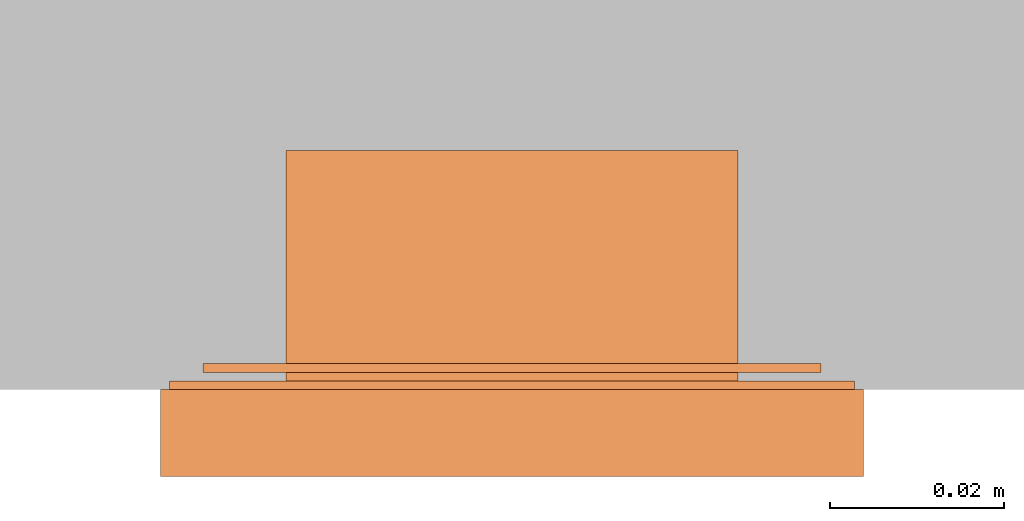
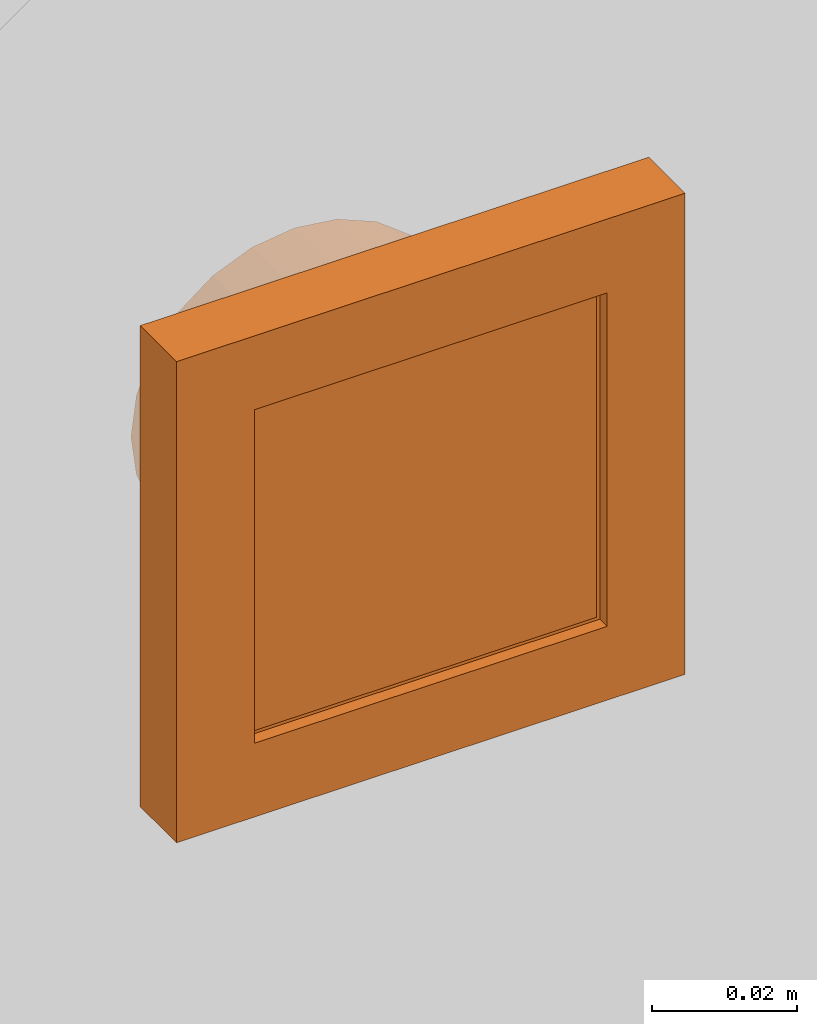
# One storey, part 2 of 2: 1 proxy.
"""IFC2X3 building model written with IfcOpenShell, lengths in metres."""

from ifc_helpers import new_model, entity, si_unit, converted_unit, derived_unit, direction, frame, origin, place, context, subcontext, project, spatial, faceted_brep, source, transform, mapped, material, type_object, type_shapes, element, save


model = new_model("IFC2X3")

# Units and contexts
model_context = context("Model", 3, precision=1e-05, world=origin(), true_north=direction((6.12303176911189e-17, 1.0)))
body_context = subcontext(model_context, "Body", "Model", "MODEL_VIEW")
ifc_project = project(units=[si_unit("LENGTHUNIT", "METRE"), si_unit("AREAUNIT", "SQUARE_METRE"), si_unit("VOLUMEUNIT", "CUBIC_METRE"), converted_unit("PLANEANGLEUNIT", "DEGREE", entity("IfcRatioMeasure", 0.0174532925199433), si_unit("PLANEANGLEUNIT", "RADIAN"), dimensions=[0, 0, 0, 0, 0, 0, 0]), si_unit("MASSUNIT", "GRAM", prefix="KILO"), si_unit("TIMEUNIT", "SECOND"), si_unit("FREQUENCYUNIT", "HERTZ"), si_unit("THERMODYNAMICTEMPERATUREUNIT", "DEGREE_CELSIUS"), derived_unit("THERMALTRANSMITTANCEUNIT", [(si_unit("MASSUNIT", "GRAM", prefix="KILO"), 1), (si_unit("THERMODYNAMICTEMPERATUREUNIT", "KELVIN"), -1), (si_unit("TIMEUNIT", "SECOND"), -3)]), derived_unit("VOLUMETRICFLOWRATEUNIT", [(si_unit("LENGTHUNIT", "METRE"), 3), (si_unit("TIMEUNIT", "SECOND"), -1)]), si_unit("ELECTRICCURRENTUNIT", "AMPERE"), si_unit("ELECTRICVOLTAGEUNIT", "VOLT"), si_unit("POWERUNIT", "WATT"), si_unit("FORCEUNIT", "NEWTON", prefix="KILO"), si_unit("ILLUMINANCEUNIT", "LUX"), si_unit("LUMINOUSFLUXUNIT", "LUMEN"), si_unit("LUMINOUSINTENSITYUNIT", "CANDELA"), derived_unit("USERDEFINED", [(si_unit("MASSUNIT", "GRAM", prefix="KILO"), -1), (si_unit("LENGTHUNIT", "METRE"), -2), (si_unit("TIMEUNIT", "SECOND"), 3), (si_unit("LUMINOUSFLUXUNIT", "LUMEN"), 1)]), derived_unit("LINEARVELOCITYUNIT", [(si_unit("LENGTHUNIT", "METRE"), 1), (si_unit("TIMEUNIT", "SECOND"), -1)]), si_unit("PRESSUREUNIT", "PASCAL"), derived_unit("USERDEFINED", [(si_unit("LENGTHUNIT", "METRE"), -2), (si_unit("MASSUNIT", "GRAM", prefix="KILO"), 1), (si_unit("TIMEUNIT", "SECOND"), -2)])], contexts=[model_context])

# Site, building, storey
site_placement = place(None, origin())
site = spatial("IfcSite", under=ifc_project, at=site_placement, CompositionType="ELEMENT")
building_placement = place(site_placement, origin())
building = spatial("IfcBuilding", under=site, at=building_placement, CompositionType="ELEMENT")
storey_placement = place(building_placement, origin())
storey = spatial("IfcBuildingStorey", under=building, at=storey_placement, Name="Ebene 0", CompositionType="ELEMENT", Elevation=0.0)

# Proxy
ifc_material = material(Name="White")
building_element_proxy_type = type_object("IfcBuildingElementProxyType", PredefinedType="NOTDEFINED", material=ifc_material)
shared_shape = source(origin(), body_context, "Body", "Brep", [
    faceted_brep([(-0.00499999999998145, -0.00934665715646335, 0.00599999999999813), (-0.00257734690540122, -0.0102818910191482, 0.00599999999999813), (0.0, -0.0106000000000252, 0.00599999999999813), (0.00257734690543831, -0.0102818910191482, 0.00599999999999813), (0.00500000000001861, -0.00934665715646362, 0.00599999999999813), (0.00500000000001861, 0.00934665715641327, 0.00599999999999813), (0.00257734690543837, 0.0102818910190978, 0.00599999999999813), (0.0, 0.0105999999999749, 0.00599999999999813), (-0.00257734690540115, 0.0102818910190978, 0.00599999999999813), (-0.00499999999998139, 0.00934665715641327, 0.00599999999999813), (-0.00257734690540115, 0.0102818910190978, -0.00600000000000187), (0.0, 0.0105999999999749, -0.00600000000000187), (0.00257734690543837, 0.0102818910190978, -0.00600000000000187), (0.00500000000001855, 0.00934665715641327, -0.00600000000000187), (0.00500000000001855, -0.00934665715646362, -0.00600000000000187), (0.00257734690543831, -0.0102818910191482, -0.00600000000000187), (0.0, -0.0106000000000252, -0.00600000000000187), (-0.00257734690540122, -0.0102818910191482, -0.00600000000000187), (-0.00499999999998139, -0.00934665715646362, -0.00600000000000187), (-0.00499999999998139, 0.00934665715641327, -0.00600000000000187)], [[[0, 1, 2, 3, 4, 5, 6, 7, 8, 9]], [[10, 11, 12, 13, 14, 15, 16, 17, 18, 19]], [[5, 4, 14, 13]], [[13, 12, 6, 5]], [[6, 12, 11, 7]], [[11, 10, 8, 7]], [[10, 19, 9, 8]], [[0, 9, 19, 18]], [[18, 17, 1, 0]], [[1, 17, 16, 2]], [[16, 15, 3, 2]], [[15, 14, 4, 3]]]),
    faceted_brep([(-0.0109999999999814, 0.0174999999999746, 0.00599999999999813), (-0.0109999999999814, 0.0164999999999746, 0.00599999999999813), (0.0110000000000187, 0.0164999999999747, 0.00599999999999813), (0.0110000000000187, 0.0174999999999747, 0.00599999999999813), (-0.0109999999999814, 0.0174999999999746, -0.00400000000000187), (-0.0109999999999814, 0.0164999999999746, -0.00400000000000187), (0.0110000000000187, 0.0164999999999747, -0.00400000000000187), (0.0110000000000187, 0.0174999999999747, -0.00400000000000187)], [[[0, 1, 2, 3]], [[1, 0, 4, 5]], [[2, 1, 5, 6]], [[3, 2, 6, 7]], [[0, 3, 7, 4]], [[4, 7, 6, 5]]]),
    faceted_brep([(0.0110000000000187, -0.0165000000000253, -0.00400000000000187), (0.0110000000000187, -0.0175000000000253, -0.00400000000000187), (-0.0109999999999814, -0.0175000000000253, -0.00400000000000187), (-0.0109999999999814, -0.0165000000000253, -0.00400000000000187), (-0.0109999999999814, -0.0165000000000253, 0.00599999999999813), (0.0110000000000187, -0.0165000000000253, 0.00599999999999813), (-0.0109999999999814, -0.0175000000000253, 0.00599999999999813), (0.0110000000000187, -0.0175000000000253, 0.00599999999999813)], [[[0, 1, 2, 3]], [[4, 5, 0, 3]], [[6, 4, 3, 2]], [[7, 6, 2, 1]], [[5, 7, 1, 0]], [[5, 4, 6, 7]]]),
    faceted_brep([(0.0275000000000185, 0.0274999999999747, 0.00799999999999813), (-0.0274999999999815, 0.0274999999999747, 0.00799999999999813), (-0.0274999999999815, -0.0275000000000253, 0.00799999999999813), (0.0275000000000185, -0.0275000000000253, 0.00799999999999813), (0.0275000000000185, 0.0274999999999747, 0.0), (0.0275000000000185, -0.0275000000000253, 0.0), (-0.0274999999999815, -0.0275000000000253, 0.0), (-0.0274999999999815, 0.0274999999999747, 0.0), (0.0260000000000186, -0.0260000000000252, 0.0), (0.0260000000000185, 0.0259999999999746, 0.0), (-0.0259999999999814, 0.0259999999999745, 0.0), (-0.0259999999999813, -0.0260000000000252, 0.0), (0.0260000000000185, -0.0260000000000252, 0.00599999999999813), (-0.0259999999999813, -0.0260000000000252, 0.00599999999999813), (-0.0259999999999814, 0.0259999999999746, 0.00599999999999813), (0.0260000000000185, 0.0259999999999746, 0.00599999999999813)], [[[0, 1, 2, 3]], [[4, 5, 6, 7], [8, 9, 10, 11]], [[1, 0, 4, 7]], [[2, 1, 7, 6]], [[3, 2, 6, 5]], [[0, 3, 5, 4]], [[12, 13, 14, 15]], [[12, 15, 9, 8]], [[15, 14, 10, 9]], [[14, 13, 11, 10]], [[13, 12, 8, 11]]]),
    faceted_brep([(0.0404000000000187, 0.0403999999999748, 0.00999999999999813), (-0.0403999999999812, 0.0403999999999748, 0.00999999999999813), (-0.0403999999999812, -0.0404000000000253, 0.00999999999999813), (0.0404000000000187, -0.0404000000000253, 0.00999999999999813), (0.0280000000000188, 0.0279999999999747, 0.00999999999999813), (0.0280000000000188, -0.0280000000000253, 0.00999999999999813), (-0.0279999999999812, -0.0280000000000253, 0.00999999999999813), (-0.0279999999999812, 0.0279999999999747, 0.00999999999999813), (0.0404000000000187, 0.0403999999999748, 0.0), (0.0404000000000187, -0.0404000000000253, 0.0), (-0.0403999999999812, -0.0404000000000253, 0.0), (-0.0403999999999812, 0.0403999999999748, 0.0), (0.0384000000000187, 0.0383999999999748, 0.0), (-0.0383999999999812, 0.0383999999999748, 0.0), (-0.0383999999999812, -0.0384000000000253, 0.0), (0.0384000000000187, -0.0384000000000253, 0.0), (0.0280000000000188, 0.0279999999999747, 0.00799999999999813), (0.0280000000000188, -0.0280000000000253, 0.00799999999999813), (-0.0279999999999812, -0.0280000000000253, 0.00799999999999813), (-0.0279999999999812, 0.0279999999999747, 0.00799999999999813), (0.0384000000000187, 0.0383999999999748, 0.00799999999999813), (0.0384000000000187, -0.0384000000000253, 0.00799999999999813), (-0.0383999999999812, -0.0384000000000253, 0.00799999999999813), (-0.0383999999999812, 0.0383999999999748, 0.00799999999999813)], [[[0, 1, 2, 3], [4, 5, 6, 7]], [[8, 9, 10, 11], [12, 13, 14, 15]], [[1, 0, 8, 11]], [[2, 1, 11, 10]], [[3, 2, 10, 9]], [[0, 3, 9, 8]], [[5, 4, 16, 17]], [[6, 5, 17, 18]], [[7, 6, 18, 19]], [[4, 7, 19, 16]], [[17, 16, 19, 18], [20, 21, 22, 23]], [[20, 23, 13, 12]], [[23, 22, 14, 13]], [[22, 21, 15, 14]], [[21, 20, 12, 15]]], outer=[[True, False], [True, False], [True], [True], [True], [True], [True], [True], [True], [True], [False, True], [True], [True], [True], [True]]),
    faceted_brep([(0.0, 0.0259999999999747, -0.0275000000000019), (0.00672929517268425, 0.0251140714834905, -0.0275000000000019), (0.0130000000000187, 0.0225166604983701, -0.0275000000000019), (0.0183847763108689, 0.0183847763108249, -0.0275000000000019), (0.0225166604984141, 0.0129999999999747, -0.0275000000000019), (0.0251140714835345, 0.00672929517264025, -0.0275000000000019), (0.0260000000000187, 0.0, -0.0275000000000019), (0.0251140714835344, -0.00672929517269098, -0.0275000000000019), (0.022516660498414, -0.0130000000000254, -0.0275000000000019), (0.0183847763108688, -0.0183847763108756, -0.0275000000000019), (0.0130000000000186, -0.0225166604984208, -0.0275000000000019), (0.00672929517268409, -0.0251140714835411, -0.0275000000000019), (0.0, -0.0260000000000253, -0.0275000000000019), (-0.00672929517264697, -0.025114071483541, -0.0275000000000019), (-0.0129999999999814, -0.0225166604984206, -0.0275000000000019), (-0.0183847763108316, -0.0183847763108755, -0.0275000000000019), (-0.0225166604983768, -0.0130000000000252, -0.0275000000000019), (-0.0251140714834971, -0.00672929517269074, -0.0275000000000019), (-0.0259999999999813, 0.0, -0.0275000000000019), (-0.0251140714834971, 0.00672929517264033, -0.0275000000000019), (-0.0225166604983767, 0.0129999999999748, -0.0275000000000019), (-0.0183847763108315, 0.018384776310825, -0.0275000000000019), (-0.0129999999999813, 0.0225166604983701, -0.0275000000000019), (-0.00672929517264682, 0.0251140714834905, -0.0275000000000019), (0.00672929517268409, -0.0251140714835411, 0.0), (0.0130000000000186, -0.0225166604984208, 0.0), (0.0183847763108688, -0.0183847763108756, 0.0), (0.022516660498414, -0.0130000000000254, 0.0), (0.0251140714835344, -0.00672929517269098, 0.0), (0.0260000000000187, 0.0, 0.0), (0.0251140714835345, 0.00672929517264025, 0.0), (0.0225166604984141, 0.0129999999999747, 0.0), (0.0183847763108689, 0.0183847763108249, 0.0), (0.0130000000000187, 0.0225166604983701, 0.0), (0.00672929517268425, 0.0251140714834905, 0.0), (0.0, 0.0259999999999747, 0.0), (-0.00672929517264682, 0.0251140714834905, 0.0), (-0.0129999999999813, 0.0225166604983701, 0.0), (-0.0183847763108315, 0.018384776310825, 0.0), (-0.0225166604983767, 0.0129999999999748, 0.0), (-0.0251140714834971, 0.00672929517264033, 0.0), (-0.0259999999999813, 0.0, 0.0), (-0.0251140714834971, -0.00672929517269074, 0.0), (-0.0225166604983768, -0.0130000000000252, 0.0), (-0.0183847763108316, -0.0183847763108755, 0.0), (-0.0129999999999814, -0.0225166604984206, 0.0), (-0.00672929517264697, -0.025114071483541, 0.0), (0.0, -0.0260000000000253, 0.0)], [[[0, 1, 2, 3, 4, 5, 6, 7, 8, 9, 10, 11, 12, 13, 14, 15, 16, 17, 18, 19, 20, 21, 22, 23]], [[24, 25, 26, 27, 28, 29, 30, 31, 32, 33, 34, 35, 36, 37, 38, 39, 40, 41, 42, 43, 44, 45, 46, 47]], [[17, 42, 41, 18]], [[16, 43, 42, 17]], [[45, 44, 15, 14]], [[16, 15, 44, 43]], [[46, 45, 14, 13]], [[47, 46, 13, 12]], [[24, 47, 12, 11]], [[27, 8, 7, 28]], [[8, 27, 26, 9]], [[28, 7, 6, 29]], [[11, 10, 25, 24]], [[25, 10, 9, 26]], [[5, 30, 29, 6]], [[4, 31, 30, 5]], [[33, 32, 3, 2]], [[4, 3, 32, 31]], [[34, 33, 2, 1]], [[35, 34, 1, 0]], [[37, 22, 21, 38]], [[39, 20, 19, 40]], [[21, 20, 39, 38]], [[18, 41, 40, 19]], [[22, 37, 36, 23]], [[36, 35, 0, 23]]]),
    faceted_brep([(0.0355000000000187, 0.0354999999999746, -0.00300000000000187), (0.0355000000000187, -0.0355000000000253, -0.00300000000000187), (-0.0354999999999812, -0.0355000000000253, -0.00300000000000187), (-0.0354999999999812, 0.0354999999999746, -0.00300000000000187), (0.0355000000000187, 0.0354999999999746, -0.00200000000000187), (-0.0354999999999812, 0.0354999999999746, -0.00200000000000187), (-0.0354999999999812, -0.0355000000000253, -0.00200000000000187), (0.0355000000000187, -0.0355000000000253, -0.00200000000000187)], [[[0, 1, 2, 3]], [[4, 5, 6, 7]], [[5, 4, 0, 3]], [[6, 5, 3, 2]], [[7, 6, 2, 1]], [[4, 7, 1, 0]]]),
    faceted_brep([(0.0394000000000188, 0.0393999999999748, -0.00100000000000187), (0.0394000000000188, -0.0394000000000252, -0.00100000000000187), (-0.0393999999999812, -0.0394000000000252, -0.00100000000000187), (-0.0393999999999812, 0.0393999999999748, -0.00100000000000187), (0.0394000000000188, 0.0393999999999748, 0.0), (-0.0393999999999812, 0.0393999999999748, 0.0), (-0.0393999999999812, -0.0394000000000252, 0.0), (0.0394000000000188, -0.0394000000000252, 0.0)], [[[0, 1, 2, 3]], [[4, 5, 6, 7]], [[5, 4, 0, 3]], [[6, 5, 3, 2]], [[7, 6, 2, 1]], [[4, 7, 1, 0]]]),
])
type_shapes(building_element_proxy_type, [shared_shape])
proxy_placement = place(storey_placement, frame((-4.37037903813241, -2.29307202699247, 1.0951421062958), z_axis=(0.0, -1.0, 0.0), x_axis=(1.0, 0.0, 0.0)))
element("IfcBuildingElementProxy", 1, at=proxy_placement, inside=storey, type_object=building_element_proxy_type, material=ifc_material, context=body_context, shape_type="MappedRepresentation", body=[
    mapped(shared_shape, transform((0.0, 0.0, 0.0), scale=1.0)),
])

save(model, "model.ifc")
